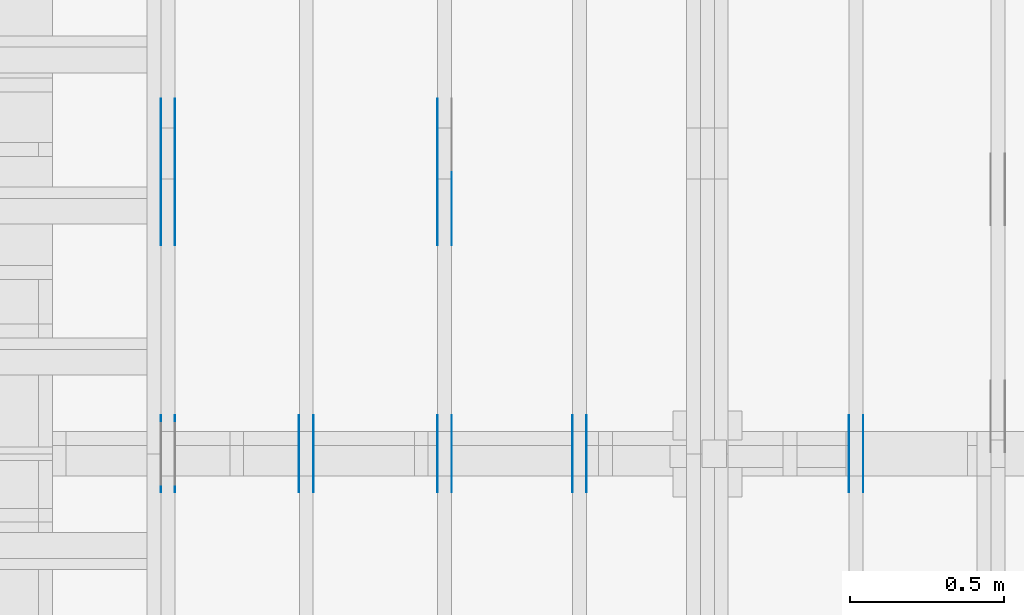
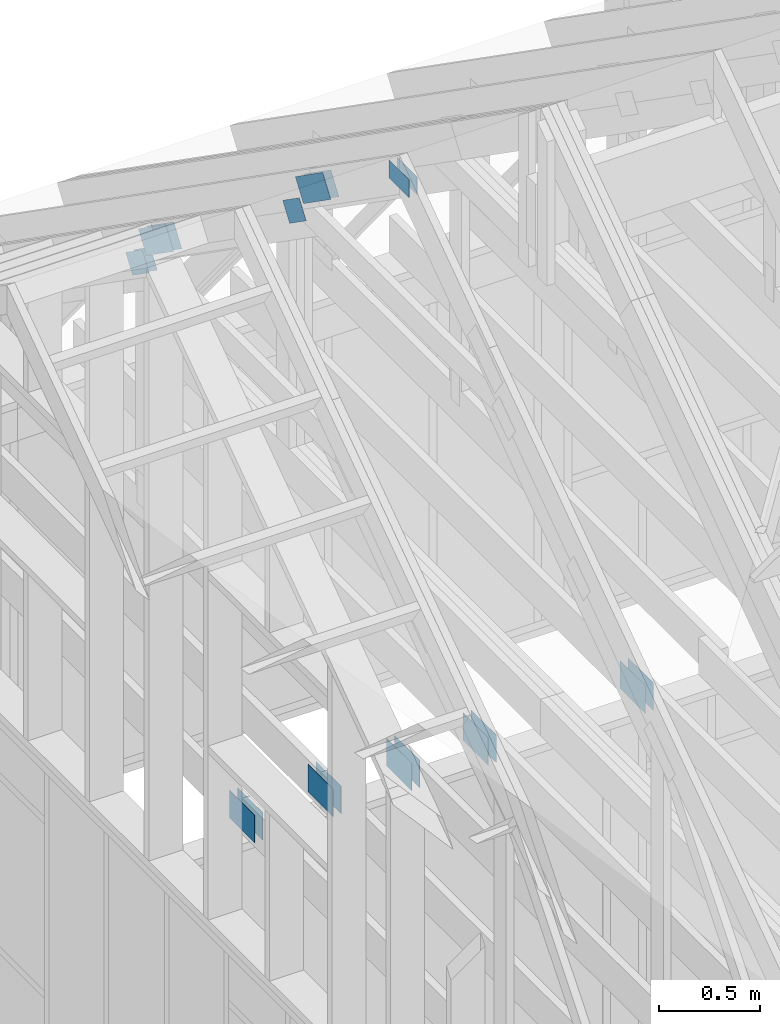
# One storey, part 47 of 70: 19 plates, 5 elements without a shape of their own.
"""IFC2X3 building model written with IfcOpenShell, lengths in millimetres."""

from ifc_helpers import new_model, si_unit, frame, origin, origin_with_axes, origin_2d, place, context, project, spatial, faceted_brep, element, aggregate, save


model = new_model("IFC2X3")

# Units and contexts
model_context = context("Model", 3, precision=1e-05, world=origin())
plan_context = context("Plan", 2, precision=1e-05, world=origin_2d())
ifc_project = project(units=[si_unit("LENGTHUNIT", "METRE", prefix="MILLI"), si_unit("AREAUNIT", "SQUARE_METRE"), si_unit("VOLUMEUNIT", "CUBIC_METRE"), si_unit("SOLIDANGLEUNIT", "STERADIAN"), si_unit("PLANEANGLEUNIT", "RADIAN"), si_unit("MASSUNIT", "GRAM"), si_unit("TIMEUNIT", "SECOND"), si_unit("THERMODYNAMICTEMPERATUREUNIT", "DEGREE_CELSIUS"), si_unit("LUMINOUSINTENSITYUNIT", "LUMEN")], contexts=[model_context, plan_context])

# Site, building, storey
site_placement = place(None, origin_with_axes())
site = spatial("IfcSite", under=ifc_project, at=site_placement, CompositionType="ELEMENT")
building_placement = place(site_placement, origin_with_axes())
building = spatial("IfcBuilding", under=site, at=building_placement, Name="Layout 1", CompositionType="ELEMENT")
storey_placement = place(building_placement, origin_with_axes())
storey = spatial("IfcBuildingStorey", under=building, at=storey_placement, Name="Storey 1", CompositionType="ELEMENT", Elevation=0.0)

# Assembly, plates
assembly_1_placement = place(storey_placement, frame((304.9999999999989, 8000.000000000001, 1.3776821480501744e-15), z_axis=(-1.0, 1.836909530733566e-16, 6.123031769111886e-17), x_axis=(-1.836909530733566e-16, -1.0, 0.0)))
assembly_1 = element("IfcElementAssembly", 1, at=assembly_1_placement, inside=storey, Name="T2", AssemblyPlace="FACTORY", PredefinedType="TRUSS")
plate_1_placement = place(assembly_1_placement, frame((3241.212504107585, 3235.9501271276167, 0.0), z_axis=(0.0, 0.0, 1.0), x_axis=(-0.8191520442889914, -0.5735764363510467, 0.0)))
plate_1 = element("IfcPlate", 2, at=plate_1_placement, context=model_context, shape_type="Brep", body=[
    faceted_brep([(330.0000000000009, 140.00000000000045, 1.5), (134.0000000000009, 140.00000000000045, 1.5), (134.0, 4.547473508864641e-13, 1.5), (330.0000000000009, 4.547473508864641e-13, 1.5), (133.9000001978775, 140.00000000000045, 1.5), (9.094947017729282e-13, 140.00000000000045, 1.5), (0.0, 4.547473508864641e-13, 1.5), (133.90000101970236, 4.547473508864641e-13, 1.5), (330.0000000000009, 140.00000000000045, 0.0), (134.0000000000009, 140.00000000000045, 0.0), (134.0, 4.547473508864641e-13, 0.0), (330.0000000000009, 4.547473508864641e-13, 0.0), (133.9000001978775, 140.00000000000045, 0.0), (9.094947017729282e-13, 140.00000000000045, 0.0), (0.0, 4.547473508864641e-13, 0.0), (133.90000101970236, 4.547473508864641e-13, 0.0), (330.0000000000009, 9.803270933743405e-13, -4.610357698653557e-29), (330.0000000000009, 9.804189388508772e-13, 1.5), (134.0, 6.682564251308046e-13, 1.5), (134.0, 6.681645796542679e-13, -4.091192948218372e-29), (133.90000101970236, 6.680053146896804e-13, 8.643095081543955e-31), (133.90000101970236, 6.680971601662171e-13, 1.5), (-1.4627915729340467e-31, 4.548391963630008e-13, 1.5), (0.0, 4.547473508864641e-13, 0.0), (133.90000101970236, 140.00000000000068, 5.032059779604519e-23), (133.90000101970236, 140.00000000000068, 1.5), (133.90000101970236, 6.821210263296962e-13, 1.5), (133.90000101970236, 6.821210263296962e-13, 0.0), (9.094947017729282e-13, 140.00000000000045, 0.0), (9.094947017729282e-13, 140.00000000000045, 1.5), (133.9000001978775, 140.00000000000068, 1.5), (133.9000001978775, 140.00000000000068, 1.5777218104420236e-30), (134.0000000000009, 140.00000000000068, 1.4199496293978212e-29), (134.0000000000009, 140.00000000000068, 1.5), (330.0000000000009, 140.00000000000102, 1.5), (330.0000000000009, 140.00000000000102, 2.208810534618833e-29), (5.56886495279458e-29, 4.547473508864641e-13, -3.409833702385498e-45), (9.184547653673398e-17, 4.547473508864641e-13, 1.5), (8.876511857361728e-13, 140.00000000000045, 1.5), (8.875593402596361e-13, 140.00000000000045, 1.3431091541284187e-30), (330.0000000000009, 140.00000000000068, 0.0), (330.0000000000009, 140.00000000000068, 1.5), (330.0000000000009, 2.2737367544323206e-13, 1.5), (330.0000000000009, 2.2737367544323206e-13, 0.0), (134.0, 0.0, 0.0), (134.0, 0.0, 1.5), (134.00000000000088, 140.00000000000045, 1.5), (134.00000000000088, 140.00000000000045, 1.5777218104420236e-30)], [[[0, 1, 2, 3]], [[4, 5, 6, 7]], [[8, 9, 10, 11]], [[12, 13, 14, 15]], [[16, 17, 18, 19]], [[20, 21, 22, 23]], [[24, 25, 26, 27]], [[28, 29, 30, 31]], [[32, 33, 34, 35]], [[36, 37, 38, 39]], [[40, 41, 42, 43]], [[44, 45, 46, 47]]]),
])
plate_2_placement = place(assembly_1_placement, frame((3241.212504107585, 3235.9501271276167, -46.5), z_axis=(0.0, 0.0, 1.0), x_axis=(-0.8191520442889914, -0.5735764363510467, 0.0)))
plate_2 = element("IfcPlate", 3, at=plate_2_placement, context=model_context, shape_type="Brep", body=[
    faceted_brep([(330.0000000000009, 140.00000000000045, 0.0), (134.0000000000009, 140.00000000000045, 0.0), (134.0, 4.547473508864641e-13, 0.0), (330.0000000000009, 4.547473508864641e-13, 0.0), (133.9000001978775, 140.00000000000045, 0.0), (9.094947017729282e-13, 140.00000000000045, 0.0), (0.0, 4.547473508864641e-13, 0.0), (133.90000101970236, 4.547473508864641e-13, 0.0), (330.0000000000009, 140.00000000000045, 1.5), (134.0000000000009, 140.00000000000045, 1.5), (134.0, 4.547473508864641e-13, 1.5), (330.0000000000009, 4.547473508864641e-13, 1.5), (133.9000001978775, 140.00000000000045, 1.5), (9.094947017729282e-13, 140.00000000000045, 1.5), (0.0, 4.547473508864641e-13, 1.5), (133.90000101970236, 4.547473508864641e-13, 1.5), (0.0, 4.547473508864641e-13, 0.0), (1.575266127070707e-31, 4.5465550540992744e-13, 1.5), (133.90000101970236, 6.843109484156988e-13, 1.5), (133.90000101970236, 6.844027938922355e-13, 1.397133527515671e-31), (134.0, 6.845743047954878e-13, 4.191670216580455e-29), (134.0, 6.844824593189511e-13, 1.5), (330.0000000000009, 1.0206472575739425e-12, 1.5), (330.0000000000009, 1.0207391030504792e-12, 4.85780171775421e-29), (133.90000101970236, 6.821210263296962e-13, 0.0), (133.90000101970236, 6.821210263296962e-13, 1.5), (133.90000019787752, 140.00000000000068, 1.5), (133.90000019787752, 140.00000000000068, 0.0), (330.0000000000009, 140.00000000000097, -1.8932661725304283e-29), (330.0000000000009, 140.00000000000097, 1.5), (134.00000000000094, 140.00000000000068, 1.5), (134.00000000000094, 140.00000000000068, -1.262177448353619e-29), (133.90000019787752, 140.00000000000068, 0.0), (133.90000019787752, 140.00000000000068, 1.5), (9.094947017729282e-13, 140.00000000000045, 1.5), (9.094947017729282e-13, 140.00000000000045, 0.0), (-2.8272774843121063e-27, 140.00000000000045, -5.568864952794597e-29), (-9.184547653950557e-17, 140.00000000000045, 1.5), (-9.184547653950557e-17, 4.547473508864641e-13, 1.5), (-2.8272774843121063e-27, 4.547473508864641e-13, -1.731150985653776e-43), (330.0000000000009, 2.2737367544323206e-13, 0.0), (330.0000000000009, 2.2737367544323206e-13, 1.5), (330.0000000000009, 140.00000000000068, 1.5), (330.0000000000009, 140.00000000000068, 0.0), (134.0, 140.00000000000045, -5.522026336547083e-29), (134.0, 140.00000000000045, 1.5), (134.0, 0.0, 1.5), (134.0, 0.0, 0.0)], [[[0, 1, 2, 3]], [[4, 5, 6, 7]], [[8, 9, 10, 11]], [[12, 13, 14, 15]], [[16, 17, 18, 19]], [[20, 21, 22, 23]], [[24, 25, 26, 27]], [[28, 29, 30, 31]], [[32, 33, 34, 35]], [[36, 37, 38, 39]], [[40, 41, 42, 43]], [[44, 45, 46, 47]]]),
])
plate_3_placement = place(assembly_1_placement, frame((4125.0, 194.0, 0.0), z_axis=(0.0, 0.0, 1.0), x_axis=(-1.0, 1.2246063538223773e-16, 0.0)))
plate_3 = element("IfcPlate", 4, at=plate_3_placement, context=model_context, shape_type="Brep", body=[
    faceted_brep([(250.0, 168.0, 1.3), (0.0, 168.0, 1.3), (0.0, 0.0, 1.3), (250.0, 0.0, 1.3), (0.0, 168.0, 0.0), (250.0, 168.0, 3.061515884555943e-14), (250.0, 0.0, 3.061515884555943e-14), (0.0, 0.0, 0.0), (250.0, -4.592273826833915e-14, 2.8118638534165077e-30), (250.0, -4.5843138855340694e-14, 1.3), (1.4621692037765842e-32, 7.959941299845453e-17, 1.3), (0.0, 0.0, 0.0), (250.0, 168.0, 0.0), (250.0, 168.0, 1.3), (250.0, 0.0, 1.3), (250.0, 0.0, 0.0), (0.0, 168.0, 0.0), (-4.8738973459219465e-33, 168.0, 1.3), (250.0, 167.99999999999997, 1.3), (250.0, 167.99999999999997, -1.5777218104420236e-30), (0.0, 0.0, 0.0), (7.959941299845453e-17, -9.747794691843893e-33, 1.3), (2.065298615721439e-14, 168.0, 1.3), (2.0573386744215938e-14, 168.0, -1.2597150063305954e-30)], [[[0, 1, 2, 3]], [[4, 5, 6, 7]], [[8, 9, 10, 11]], [[12, 13, 14, 15]], [[16, 17, 18, 19]], [[20, 21, 22, 23]]]),
])
plate_4_placement = place(assembly_1_placement, frame((4125.0, 194.0, -46.3), z_axis=(0.0, 0.0, 1.0), x_axis=(-1.0, 1.2246063538223773e-16, 0.0)))
plate_4 = element("IfcPlate", 5, at=plate_4_placement, context=model_context, shape_type="Brep", body=[
    faceted_brep([(250.0, 168.0, 1.2999999999999972), (0.0, 168.0, 1.2999999999999972), (0.0, 0.0, 1.2999999999999972), (250.0, 0.0, 1.2999999999999972), (0.0, 168.0, 0.0), (250.0, 168.0, 3.061515884555943e-14), (250.0, 0.0, 3.061515884555943e-14), (0.0, 0.0, 0.0), (250.0, -4.592273826833915e-14, 2.8118638534165077e-30), (250.0, -4.5843138855340694e-14, 1.2999999999999972), (1.462169203776581e-32, 7.959941299845434e-17, 1.2999999999999972), (0.0, 0.0, 0.0), (250.0, 168.0, 0.0), (250.0, 168.0, 1.2999999999999972), (250.0, 0.0, 1.2999999999999972), (250.0, 0.0, 0.0), (0.0, 168.0, 0.0), (-4.873897345921936e-33, 168.0, 1.2999999999999972), (250.0, 167.99999999999997, 1.2999999999999972), (250.0, 167.99999999999997, -1.5777218104420236e-30), (0.0, 0.0, 0.0), (7.959941299845434e-17, -9.747794691843873e-33, 1.2999999999999972), (2.065298615721439e-14, 168.0, 1.2999999999999972), (2.0573386744215938e-14, 168.0, -1.2597150063305954e-30)], [[[0, 1, 2, 3]], [[4, 5, 6, 7]], [[8, 9, 10, 11]], [[12, 13, 14, 15]], [[16, 17, 18, 19]], [[20, 21, 22, 23]]]),
])
plate_5_placement = place(assembly_1_placement, frame((2913.5449336778356, 2728.78860534236, 0.0), z_axis=(0.0, 0.0, 1.0), x_axis=(0.8191520442889915, 0.5735764363510465, 0.0)))
plate_5 = element("IfcPlate", 6, at=plate_5_placement, context=model_context, shape_type="Brep", body=[
    faceted_brep([(200.0, 120.00000000000023, 1.3), (0.0, 120.00000000000023, 1.3), (0.0, 0.0, 1.3), (200.0, 0.0, 1.3), (0.0, 120.00000000000023, 0.0), (200.0, 120.00000000000023, 2.4492127076447545e-14), (200.0, 4.547473508864641e-13, 2.4492127076447545e-14), (0.0, 4.547473508864641e-13, 0.0), (200.0, 3.185331772653788e-13, 8.340437124852278e-30), (200.0, 3.186127766783772e-13, 1.3), (-1.2677526965428406e-31, 7.959941299845453e-17, 1.3), (0.0, 0.0, 0.0), (200.0, 120.00000000000023, 0.0), (200.0, 120.00000000000023, 1.3), (200.0, 4.547473508864641e-13, 1.3), (200.0, 4.547473508864641e-13, 0.0), (0.0, 120.00000000000023, 0.0), (-4.8738973459219465e-33, 120.00000000000023, 1.3), (200.0, 120.00000000000021, 1.3), (200.0, 120.00000000000021, 0.0), (0.0, 0.0, 0.0), (7.959941299845453e-17, -9.747794691843893e-33, 1.3), (1.477487565886701e-14, 120.00000000000023, 1.3), (1.4695276245868555e-14, 120.00000000000023, -8.997964330932842e-31)], [[[0, 1, 2, 3]], [[4, 5, 6, 7]], [[8, 9, 10, 11]], [[12, 13, 14, 15]], [[16, 17, 18, 19]], [[20, 21, 22, 23]]]),
])
plate_6_placement = place(assembly_1_placement, frame((2913.5449336778356, 2728.78860534236, -46.29999999999999), z_axis=(0.0, 0.0, 1.0), x_axis=(0.8191520442889915, 0.5735764363510465, 0.0)))
plate_6 = element("IfcPlate", 7, at=plate_6_placement, context=model_context, shape_type="Brep", body=[
    faceted_brep([(200.0, 120.00000000000023, 1.2999999999999972), (0.0, 120.00000000000023, 1.2999999999999972), (0.0, 0.0, 1.2999999999999972), (200.0, 0.0, 1.2999999999999972), (0.0, 120.00000000000023, 0.0), (200.0, 120.00000000000023, 2.4492127076447545e-14), (200.0, 4.547473508864641e-13, 2.4492127076447545e-14), (0.0, 4.547473508864641e-13, 0.0), (200.0, 3.185331772653788e-13, 8.340437124852278e-30), (200.0, 3.186127766783772e-13, 1.2999999999999972), (-1.2677526965428377e-31, 7.959941299845434e-17, 1.2999999999999972), (0.0, 0.0, 0.0), (200.0, 120.00000000000023, 0.0), (200.0, 120.00000000000023, 1.2999999999999972), (200.0, 4.547473508864641e-13, 1.2999999999999972), (200.0, 4.547473508864641e-13, 0.0), (0.0, 120.00000000000023, 0.0), (-4.873897345921936e-33, 120.00000000000023, 1.2999999999999972), (200.0, 120.00000000000021, 1.2999999999999972), (200.0, 120.00000000000021, 0.0), (0.0, 0.0, 0.0), (7.959941299845434e-17, -9.747794691843873e-33, 1.2999999999999972), (1.477487565886701e-14, 120.00000000000023, 1.2999999999999972), (1.4695276245868555e-14, 120.00000000000023, -8.997964330932842e-31)], [[[0, 1, 2, 3]], [[4, 5, 6, 7]], [[8, 9, 10, 11]], [[12, 13, 14, 15]], [[16, 17, 18, 19]], [[20, 21, 22, 23]]]),
])
aggregate(assembly_1, [plate_1, plate_2, plate_3, plate_4, plate_5, plate_6])

assembly_2_placement = place(storey_placement, frame((1204.9999999999989, 8000.000000000001, 1.3776821480501744e-15), z_axis=(-1.0, 1.836909530733566e-16, 6.123031769111886e-17), x_axis=(-1.836909530733566e-16, -1.0, 0.0)))
assembly_2 = element("IfcElementAssembly", 8, at=assembly_2_placement, inside=storey, Name="T2", AssemblyPlace="FACTORY", PredefinedType="TRUSS")
plate_7_placement = place(assembly_2_placement, frame((3241.212504107585, 3235.9501271276167, 0.0), z_axis=(0.0, 0.0, 1.0), x_axis=(-0.8191520442889914, -0.5735764363510467, 0.0)))
plate_7 = element("IfcPlate", 9, at=plate_7_placement, context=model_context, shape_type="Brep", body=[
    faceted_brep([(330.0000000000009, 140.00000000000045, 1.5), (134.0000000000009, 140.00000000000045, 1.5), (134.0, 4.547473508864641e-13, 1.5), (330.0000000000009, 4.547473508864641e-13, 1.5), (133.9000001978775, 140.00000000000045, 1.5), (9.094947017729282e-13, 140.00000000000045, 1.5), (0.0, 4.547473508864641e-13, 1.5), (133.90000101970236, 4.547473508864641e-13, 1.5), (330.0000000000009, 140.00000000000045, 0.0), (134.0000000000009, 140.00000000000045, 0.0), (134.0, 4.547473508864641e-13, 0.0), (330.0000000000009, 4.547473508864641e-13, 0.0), (133.9000001978775, 140.00000000000045, 0.0), (9.094947017729282e-13, 140.00000000000045, 0.0), (0.0, 4.547473508864641e-13, 0.0), (133.90000101970236, 4.547473508864641e-13, 0.0), (330.0000000000009, 9.803270933743405e-13, -4.610357698653557e-29), (330.0000000000009, 9.804189388508772e-13, 1.5), (134.0, 6.682564251308046e-13, 1.5), (134.0, 6.681645796542679e-13, -4.091192948218372e-29), (133.90000101970236, 6.680053146896804e-13, 8.643095081543955e-31), (133.90000101970236, 6.680971601662171e-13, 1.5), (-1.4627915729340467e-31, 4.548391963630008e-13, 1.5), (0.0, 4.547473508864641e-13, 0.0), (133.90000101970236, 140.00000000000068, 5.032059779604519e-23), (133.90000101970236, 140.00000000000068, 1.5), (133.90000101970236, 6.821210263296962e-13, 1.5), (133.90000101970236, 6.821210263296962e-13, 0.0), (9.094947017729282e-13, 140.00000000000045, 0.0), (9.094947017729282e-13, 140.00000000000045, 1.5), (133.9000001978775, 140.00000000000068, 1.5), (133.9000001978775, 140.00000000000068, 1.5777218104420236e-30), (134.0000000000009, 140.00000000000068, 1.4199496293978212e-29), (134.0000000000009, 140.00000000000068, 1.5), (330.0000000000009, 140.00000000000102, 1.5), (330.0000000000009, 140.00000000000102, 2.208810534618833e-29), (5.56886495279458e-29, 4.547473508864641e-13, -3.409833702385498e-45), (9.184547653673398e-17, 4.547473508864641e-13, 1.5), (8.876511857361728e-13, 140.00000000000045, 1.5), (8.875593402596361e-13, 140.00000000000045, 1.3431091541284187e-30), (330.0000000000009, 140.00000000000068, 0.0), (330.0000000000009, 140.00000000000068, 1.5), (330.0000000000009, 2.2737367544323206e-13, 1.5), (330.0000000000009, 2.2737367544323206e-13, 0.0), (134.0, 0.0, 0.0), (134.0, 0.0, 1.5), (134.00000000000088, 140.00000000000045, 1.5), (134.00000000000088, 140.00000000000045, 1.5777218104420236e-30)], [[[0, 1, 2, 3]], [[4, 5, 6, 7]], [[8, 9, 10, 11]], [[12, 13, 14, 15]], [[16, 17, 18, 19]], [[20, 21, 22, 23]], [[24, 25, 26, 27]], [[28, 29, 30, 31]], [[32, 33, 34, 35]], [[36, 37, 38, 39]], [[40, 41, 42, 43]], [[44, 45, 46, 47]]]),
])
plate_8_placement = place(assembly_2_placement, frame((3241.212504107585, 3235.9501271276167, -46.5), z_axis=(0.0, 0.0, 1.0), x_axis=(-0.8191520442889914, -0.5735764363510467, 0.0)))
plate_8 = element("IfcPlate", 10, at=plate_8_placement, context=model_context, shape_type="Brep", body=[
    faceted_brep([(330.0000000000009, 140.00000000000045, 0.0), (134.0000000000009, 140.00000000000045, 0.0), (134.0, 4.547473508864641e-13, 0.0), (330.0000000000009, 4.547473508864641e-13, 0.0), (133.9000001978775, 140.00000000000045, 0.0), (9.094947017729282e-13, 140.00000000000045, 0.0), (0.0, 4.547473508864641e-13, 0.0), (133.90000101970236, 4.547473508864641e-13, 0.0), (330.0000000000009, 140.00000000000045, 1.5), (134.0000000000009, 140.00000000000045, 1.5), (134.0, 4.547473508864641e-13, 1.5), (330.0000000000009, 4.547473508864641e-13, 1.5), (133.9000001978775, 140.00000000000045, 1.5), (9.094947017729282e-13, 140.00000000000045, 1.5), (0.0, 4.547473508864641e-13, 1.5), (133.90000101970236, 4.547473508864641e-13, 1.5), (0.0, 4.547473508864641e-13, 0.0), (1.575266127070707e-31, 4.5465550540992744e-13, 1.5), (133.90000101970236, 6.843109484156988e-13, 1.5), (133.90000101970236, 6.844027938922355e-13, 1.397133527515671e-31), (134.0, 6.845743047954878e-13, 4.191670216580455e-29), (134.0, 6.844824593189511e-13, 1.5), (330.0000000000009, 1.0206472575739425e-12, 1.5), (330.0000000000009, 1.0207391030504792e-12, 4.85780171775421e-29), (133.90000101970236, 6.821210263296962e-13, 0.0), (133.90000101970236, 6.821210263296962e-13, 1.5), (133.90000019787752, 140.00000000000068, 1.5), (133.90000019787752, 140.00000000000068, 0.0), (330.0000000000009, 140.00000000000097, -1.8932661725304283e-29), (330.0000000000009, 140.00000000000097, 1.5), (134.00000000000094, 140.00000000000068, 1.5), (134.00000000000094, 140.00000000000068, -1.262177448353619e-29), (133.90000019787752, 140.00000000000068, 0.0), (133.90000019787752, 140.00000000000068, 1.5), (9.094947017729282e-13, 140.00000000000045, 1.5), (9.094947017729282e-13, 140.00000000000045, 0.0), (-2.8272774843121063e-27, 140.00000000000045, -5.568864952794597e-29), (-9.184547653950557e-17, 140.00000000000045, 1.5), (-9.184547653950557e-17, 4.547473508864641e-13, 1.5), (-2.8272774843121063e-27, 4.547473508864641e-13, -1.731150985653776e-43), (330.0000000000009, 2.2737367544323206e-13, 0.0), (330.0000000000009, 2.2737367544323206e-13, 1.5), (330.0000000000009, 140.00000000000068, 1.5), (330.0000000000009, 140.00000000000068, 0.0), (134.0, 140.00000000000045, -5.522026336547083e-29), (134.0, 140.00000000000045, 1.5), (134.0, 0.0, 1.5), (134.0, 0.0, 0.0)], [[[0, 1, 2, 3]], [[4, 5, 6, 7]], [[8, 9, 10, 11]], [[12, 13, 14, 15]], [[16, 17, 18, 19]], [[20, 21, 22, 23]], [[24, 25, 26, 27]], [[28, 29, 30, 31]], [[32, 33, 34, 35]], [[36, 37, 38, 39]], [[40, 41, 42, 43]], [[44, 45, 46, 47]]]),
])
plate_9_placement = place(assembly_2_placement, frame((3899.9999999999995, 3603.8046304341406, 0.0), z_axis=(0.0, 0.0, 1.0), x_axis=(1.0, 0.0, 0.0)))
plate_9 = element("IfcPlate", 11, at=plate_9_placement, context=model_context, shape_type="Brep", body=[
    faceted_brep([(200.00000000000045, 108.0, 1.3), (0.0, 108.0, 1.3), (0.0, 0.0, 1.3), (200.00000000000045, 0.0, 1.3), (0.0, 108.0, 0.0), (200.00000000000045, 108.0, 2.4492127076447602e-14), (200.00000000000045, 0.0, 2.4492127076447602e-14), (0.0, 0.0, 0.0), (200.00000000000045, -3.67381906146714e-14, 2.2494910827332114e-30), (200.00000000000045, -3.6658591201672947e-14, 1.3), (1.4621692037765842e-32, 7.959941299845453e-17, 1.3), (0.0, 0.0, 0.0), (200.00000000000045, 108.0, 0.0), (200.00000000000045, 108.0, 1.3), (200.00000000000045, 0.0, 1.3), (200.00000000000045, 0.0, 0.0), (0.0, 108.0, 0.0), (-4.8738973459219465e-33, 108.0, 1.3), (200.00000000000045, 107.99999999999999, 1.3), (200.00000000000045, 107.99999999999999, -7.888609052210118e-31), (0.0, 0.0, 0.0), (7.959941299845453e-17, -9.747794691843893e-33, 1.3), (1.330534803428013e-14, 108.0, 1.3), (1.3225748621281674e-14, 108.0, -8.098167897839542e-31)], [[[0, 1, 2, 3]], [[4, 5, 6, 7]], [[8, 9, 10, 11]], [[12, 13, 14, 15]], [[16, 17, 18, 19]], [[20, 21, 22, 23]]]),
])
plate_10_placement = place(assembly_2_placement, frame((3899.9999999999995, 3603.8046304341406, -46.3), z_axis=(0.0, 0.0, 1.0), x_axis=(1.0, 0.0, 0.0)))
plate_10 = element("IfcPlate", 12, at=plate_10_placement, context=model_context, shape_type="Brep", body=[
    faceted_brep([(200.00000000000045, 108.0, 1.2999999999999972), (0.0, 108.0, 1.2999999999999972), (0.0, 0.0, 1.2999999999999972), (200.00000000000045, 0.0, 1.2999999999999972), (0.0, 108.0, 0.0), (200.00000000000045, 108.0, 2.4492127076447602e-14), (200.00000000000045, 0.0, 2.4492127076447602e-14), (0.0, 0.0, 0.0), (200.00000000000045, -3.67381906146714e-14, 2.2494910827332114e-30), (200.00000000000045, -3.6658591201672947e-14, 1.2999999999999972), (1.462169203776581e-32, 7.959941299845434e-17, 1.2999999999999972), (0.0, 0.0, 0.0), (200.00000000000045, 108.0, 0.0), (200.00000000000045, 108.0, 1.2999999999999972), (200.00000000000045, 0.0, 1.2999999999999972), (200.00000000000045, 0.0, 0.0), (0.0, 108.0, 0.0), (-4.873897345921936e-33, 108.0, 1.2999999999999972), (200.00000000000045, 107.99999999999999, 1.2999999999999972), (200.00000000000045, 107.99999999999999, -7.888609052210118e-31), (0.0, 0.0, 0.0), (7.959941299845434e-17, -9.747794691843873e-33, 1.2999999999999972), (1.330534803428013e-14, 108.0, 1.2999999999999972), (1.3225748621281674e-14, 108.0, -8.098167897839542e-31)], [[[0, 1, 2, 3]], [[4, 5, 6, 7]], [[8, 9, 10, 11]], [[12, 13, 14, 15]], [[16, 17, 18, 19]], [[20, 21, 22, 23]]]),
])
plate_11_placement = place(assembly_2_placement, frame((4125.0, 194.0, 0.0), z_axis=(0.0, 0.0, 1.0), x_axis=(-1.0, 1.2246063538223773e-16, 0.0)))
plate_11 = element("IfcPlate", 13, at=plate_11_placement, context=model_context, shape_type="Brep", body=[
    faceted_brep([(250.0, 168.0, 1.3), (0.0, 168.0, 1.3), (0.0, 0.0, 1.3), (250.0, 0.0, 1.3), (0.0, 168.0, 0.0), (250.0, 168.0, 3.061515884555943e-14), (250.0, 0.0, 3.061515884555943e-14), (0.0, 0.0, 0.0), (250.0, -4.592273826833915e-14, 2.8118638534165077e-30), (250.0, -4.5843138855340694e-14, 1.3), (1.4621692037765842e-32, 7.959941299845453e-17, 1.3), (0.0, 0.0, 0.0), (250.0, 168.0, 0.0), (250.0, 168.0, 1.3), (250.0, 0.0, 1.3), (250.0, 0.0, 0.0), (0.0, 168.0, 0.0), (-4.8738973459219465e-33, 168.0, 1.3), (250.0, 167.99999999999997, 1.3), (250.0, 167.99999999999997, -1.5777218104420236e-30), (0.0, 0.0, 0.0), (7.959941299845453e-17, -9.747794691843893e-33, 1.3), (2.065298615721439e-14, 168.0, 1.3), (2.0573386744215938e-14, 168.0, -1.2597150063305954e-30)], [[[0, 1, 2, 3]], [[4, 5, 6, 7]], [[8, 9, 10, 11]], [[12, 13, 14, 15]], [[16, 17, 18, 19]], [[20, 21, 22, 23]]]),
])
plate_12_placement = place(assembly_2_placement, frame((4125.0, 194.0, -46.3), z_axis=(0.0, 0.0, 1.0), x_axis=(-1.0, 1.2246063538223773e-16, 0.0)))
plate_12 = element("IfcPlate", 14, at=plate_12_placement, context=model_context, shape_type="Brep", body=[
    faceted_brep([(250.0, 168.0, 1.2999999999999972), (0.0, 168.0, 1.2999999999999972), (0.0, 0.0, 1.2999999999999972), (250.0, 0.0, 1.2999999999999972), (0.0, 168.0, 0.0), (250.0, 168.0, 3.061515884555943e-14), (250.0, 0.0, 3.061515884555943e-14), (0.0, 0.0, 0.0), (250.0, -4.592273826833915e-14, 2.8118638534165077e-30), (250.0, -4.5843138855340694e-14, 1.2999999999999972), (1.462169203776581e-32, 7.959941299845434e-17, 1.2999999999999972), (0.0, 0.0, 0.0), (250.0, 168.0, 0.0), (250.0, 168.0, 1.2999999999999972), (250.0, 0.0, 1.2999999999999972), (250.0, 0.0, 0.0), (0.0, 168.0, 0.0), (-4.873897345921936e-33, 168.0, 1.2999999999999972), (250.0, 167.99999999999997, 1.2999999999999972), (250.0, 167.99999999999997, -1.5777218104420236e-30), (0.0, 0.0, 0.0), (7.959941299845434e-17, -9.747794691843873e-33, 1.2999999999999972), (2.065298615721439e-14, 168.0, 1.2999999999999972), (2.0573386744215938e-14, 168.0, -1.2597150063305954e-30)], [[[0, 1, 2, 3]], [[4, 5, 6, 7]], [[8, 9, 10, 11]], [[12, 13, 14, 15]], [[16, 17, 18, 19]], [[20, 21, 22, 23]]]),
])
plate_13_placement = place(assembly_2_placement, frame((2913.5449336778356, 2728.78860534236, 0.0), z_axis=(0.0, 0.0, 1.0), x_axis=(0.8191520442889915, 0.5735764363510465, 0.0)))
plate_13 = element("IfcPlate", 15, at=plate_13_placement, context=model_context, shape_type="Brep", body=[
    faceted_brep([(200.0, 120.00000000000023, 1.3), (0.0, 120.00000000000023, 1.3), (0.0, 0.0, 1.3), (200.0, 0.0, 1.3), (0.0, 120.00000000000023, 0.0), (200.0, 120.00000000000023, 2.4492127076447545e-14), (200.0, 4.547473508864641e-13, 2.4492127076447545e-14), (0.0, 4.547473508864641e-13, 0.0), (200.0, 3.185331772653788e-13, 8.340437124852278e-30), (200.0, 3.186127766783772e-13, 1.3), (-1.2677526965428406e-31, 7.959941299845453e-17, 1.3), (0.0, 0.0, 0.0), (200.0, 120.00000000000023, 0.0), (200.0, 120.00000000000023, 1.3), (200.0, 4.547473508864641e-13, 1.3), (200.0, 4.547473508864641e-13, 0.0), (0.0, 120.00000000000023, 0.0), (-4.8738973459219465e-33, 120.00000000000023, 1.3), (200.0, 120.00000000000021, 1.3), (200.0, 120.00000000000021, 0.0), (0.0, 0.0, 0.0), (7.959941299845453e-17, -9.747794691843893e-33, 1.3), (1.477487565886701e-14, 120.00000000000023, 1.3), (1.4695276245868555e-14, 120.00000000000023, -8.997964330932842e-31)], [[[0, 1, 2, 3]], [[4, 5, 6, 7]], [[8, 9, 10, 11]], [[12, 13, 14, 15]], [[16, 17, 18, 19]], [[20, 21, 22, 23]]]),
])
aggregate(assembly_2, [plate_7, plate_8, plate_9, plate_10, plate_11, plate_12, plate_13])

assembly_3_placement = place(storey_placement, frame((754.9999999999991, 8000.000000000001, 1.3776821480501744e-15), z_axis=(-1.0, 1.836909530733566e-16, 6.123031769111886e-17), x_axis=(-1.836909530733566e-16, -1.0, 0.0)))
assembly_3 = element("IfcElementAssembly", 16, at=assembly_3_placement, inside=storey, Name="MB1", AssemblyPlace="FACTORY", PredefinedType="TRUSS")
plate_14_placement = place(assembly_3_placement, frame((4125.0, 193.99999999999994, 0.0), z_axis=(0.0, 0.0, 1.0), x_axis=(-1.0, 1.2246063538223773e-16, 0.0)))
plate_14 = element("IfcPlate", 17, at=plate_14_placement, context=model_context, shape_type="Brep", body=[
    faceted_brep([(250.0, 168.0, 1.3), (0.0, 168.0, 1.3), (0.0, 0.0, 1.3), (250.0, 0.0, 1.3), (0.0, 168.0, 0.0), (250.0, 168.0, 3.061515884555943e-14), (250.0, 0.0, 3.061515884555943e-14), (0.0, 0.0, 0.0), (250.0, -4.592273826833915e-14, 2.8118638534165077e-30), (250.0, -4.5843138855340694e-14, 1.3), (1.4621692037765842e-32, 7.959941299845453e-17, 1.3), (0.0, 0.0, 0.0), (250.0, 168.0, 0.0), (250.0, 168.0, 1.3), (250.0, 0.0, 1.3), (250.0, 0.0, 0.0), (0.0, 168.0, 0.0), (-4.8738973459219465e-33, 168.0, 1.3), (250.0, 167.99999999999997, 1.3), (250.0, 167.99999999999997, -1.5777218104420236e-30), (0.0, 0.0, 0.0), (7.959941299845453e-17, -9.747794691843893e-33, 1.3), (2.065298615721439e-14, 168.0, 1.3), (2.0573386744215938e-14, 168.0, -1.2597150063305954e-30)], [[[0, 1, 2, 3]], [[4, 5, 6, 7]], [[8, 9, 10, 11]], [[12, 13, 14, 15]], [[16, 17, 18, 19]], [[20, 21, 22, 23]]]),
])
plate_15_placement = place(assembly_3_placement, frame((4125.0, 193.99999999999994, -46.3), z_axis=(0.0, 0.0, 1.0), x_axis=(-1.0, 1.2246063538223773e-16, 0.0)))
plate_15 = element("IfcPlate", 18, at=plate_15_placement, context=model_context, shape_type="Brep", body=[
    faceted_brep([(250.0, 168.0, 1.2999999999999972), (0.0, 168.0, 1.2999999999999972), (0.0, 0.0, 1.2999999999999972), (250.0, 0.0, 1.2999999999999972), (0.0, 168.0, 0.0), (250.0, 168.0, 3.061515884555943e-14), (250.0, 0.0, 3.061515884555943e-14), (0.0, 0.0, 0.0), (250.0, -4.592273826833915e-14, 2.8118638534165077e-30), (250.0, -4.5843138855340694e-14, 1.2999999999999972), (1.462169203776581e-32, 7.959941299845434e-17, 1.2999999999999972), (0.0, 0.0, 0.0), (250.0, 168.0, 0.0), (250.0, 168.0, 1.2999999999999972), (250.0, 0.0, 1.2999999999999972), (250.0, 0.0, 0.0), (0.0, 168.0, 0.0), (-4.873897345921936e-33, 168.0, 1.2999999999999972), (250.0, 167.99999999999997, 1.2999999999999972), (250.0, 167.99999999999997, -1.5777218104420236e-30), (0.0, 0.0, 0.0), (7.959941299845434e-17, -9.747794691843873e-33, 1.2999999999999972), (2.065298615721439e-14, 168.0, 1.2999999999999972), (2.0573386744215938e-14, 168.0, -1.2597150063305954e-30)], [[[0, 1, 2, 3]], [[4, 5, 6, 7]], [[8, 9, 10, 11]], [[12, 13, 14, 15]], [[16, 17, 18, 19]], [[20, 21, 22, 23]]]),
])
aggregate(assembly_3, [plate_14, plate_15])

assembly_4_placement = place(storey_placement, frame((1643.7499999999982, 8000.000000000001, 1.3776821480501744e-15), z_axis=(-1.0, 1.836909530733566e-16, 6.123031769111886e-17), x_axis=(-1.836909530733566e-16, -1.0, 0.0)))
assembly_4 = element("IfcElementAssembly", 19, at=assembly_4_placement, inside=storey, Name="MB1", AssemblyPlace="FACTORY", PredefinedType="TRUSS")
plate_16_placement = place(assembly_4_placement, frame((4125.0, 193.99999999999994, 0.0), z_axis=(0.0, 0.0, 1.0), x_axis=(-1.0, 1.2246063538223773e-16, 0.0)))
plate_16 = element("IfcPlate", 20, at=plate_16_placement, context=model_context, shape_type="Brep", body=[
    faceted_brep([(250.0, 168.0, 1.3), (0.0, 168.0, 1.3), (0.0, 0.0, 1.3), (250.0, 0.0, 1.3), (0.0, 168.0, 0.0), (250.0, 168.0, 3.061515884555943e-14), (250.0, 0.0, 3.061515884555943e-14), (0.0, 0.0, 0.0), (250.0, -4.592273826833915e-14, 2.8118638534165077e-30), (250.0, -4.5843138855340694e-14, 1.3), (1.4621692037765842e-32, 7.959941299845453e-17, 1.3), (0.0, 0.0, 0.0), (250.0, 168.0, 0.0), (250.0, 168.0, 1.3), (250.0, 0.0, 1.3), (250.0, 0.0, 0.0), (0.0, 168.0, 0.0), (-4.8738973459219465e-33, 168.0, 1.3), (250.0, 167.99999999999997, 1.3), (250.0, 167.99999999999997, -1.5777218104420236e-30), (0.0, 0.0, 0.0), (7.959941299845453e-17, -9.747794691843893e-33, 1.3), (2.065298615721439e-14, 168.0, 1.3), (2.0573386744215938e-14, 168.0, -1.2597150063305954e-30)], [[[0, 1, 2, 3]], [[4, 5, 6, 7]], [[8, 9, 10, 11]], [[12, 13, 14, 15]], [[16, 17, 18, 19]], [[20, 21, 22, 23]]]),
])
plate_17_placement = place(assembly_4_placement, frame((4125.0, 193.99999999999994, -46.3), z_axis=(0.0, 0.0, 1.0), x_axis=(-1.0, 1.2246063538223773e-16, 0.0)))
plate_17 = element("IfcPlate", 21, at=plate_17_placement, context=model_context, shape_type="Brep", body=[
    faceted_brep([(250.0, 168.0, 1.2999999999999972), (0.0, 168.0, 1.2999999999999972), (0.0, 0.0, 1.2999999999999972), (250.0, 0.0, 1.2999999999999972), (0.0, 168.0, 0.0), (250.0, 168.0, 3.061515884555943e-14), (250.0, 0.0, 3.061515884555943e-14), (0.0, 0.0, 0.0), (250.0, -4.592273826833915e-14, 2.8118638534165077e-30), (250.0, -4.5843138855340694e-14, 1.2999999999999972), (1.462169203776581e-32, 7.959941299845434e-17, 1.2999999999999972), (0.0, 0.0, 0.0), (250.0, 168.0, 0.0), (250.0, 168.0, 1.2999999999999972), (250.0, 0.0, 1.2999999999999972), (250.0, 0.0, 0.0), (0.0, 168.0, 0.0), (-4.873897345921936e-33, 168.0, 1.2999999999999972), (250.0, 167.99999999999997, 1.2999999999999972), (250.0, 167.99999999999997, -1.5777218104420236e-30), (0.0, 0.0, 0.0), (7.959941299845434e-17, -9.747794691843873e-33, 1.2999999999999972), (2.065298615721439e-14, 168.0, 1.2999999999999972), (2.0573386744215938e-14, 168.0, -1.2597150063305954e-30)], [[[0, 1, 2, 3]], [[4, 5, 6, 7]], [[8, 9, 10, 11]], [[12, 13, 14, 15]], [[16, 17, 18, 19]], [[20, 21, 22, 23]]]),
])
aggregate(assembly_4, [plate_16, plate_17])

assembly_5_placement = place(storey_placement, frame((2543.749999999999, 8000.000000000001, 1.3776821480501744e-15), z_axis=(-1.0, 1.836909530733566e-16, 6.123031769111886e-17), x_axis=(-1.836909530733566e-16, -1.0, 0.0)))
assembly_5 = element("IfcElementAssembly", 22, at=assembly_5_placement, inside=storey, Name="MB1", AssemblyPlace="FACTORY", PredefinedType="TRUSS")
plate_18_placement = place(assembly_5_placement, frame((4125.0, 193.99999999999994, 0.0), z_axis=(0.0, 0.0, 1.0), x_axis=(-1.0, 1.2246063538223773e-16, 0.0)))
plate_18 = element("IfcPlate", 23, at=plate_18_placement, context=model_context, shape_type="Brep", body=[
    faceted_brep([(250.0, 168.0, 1.3), (0.0, 168.0, 1.3), (0.0, 0.0, 1.3), (250.0, 0.0, 1.3), (0.0, 168.0, 0.0), (250.0, 168.0, 3.061515884555943e-14), (250.0, 0.0, 3.061515884555943e-14), (0.0, 0.0, 0.0), (250.0, -4.592273826833915e-14, 2.8118638534165077e-30), (250.0, -4.5843138855340694e-14, 1.3), (1.4621692037765842e-32, 7.959941299845453e-17, 1.3), (0.0, 0.0, 0.0), (250.0, 168.0, 0.0), (250.0, 168.0, 1.3), (250.0, 0.0, 1.3), (250.0, 0.0, 0.0), (0.0, 168.0, 0.0), (-4.8738973459219465e-33, 168.0, 1.3), (250.0, 167.99999999999997, 1.3), (250.0, 167.99999999999997, -1.5777218104420236e-30), (0.0, 0.0, 0.0), (7.959941299845453e-17, -9.747794691843893e-33, 1.3), (2.065298615721439e-14, 168.0, 1.3), (2.0573386744215938e-14, 168.0, -1.2597150063305954e-30)], [[[0, 1, 2, 3]], [[4, 5, 6, 7]], [[8, 9, 10, 11]], [[12, 13, 14, 15]], [[16, 17, 18, 19]], [[20, 21, 22, 23]]]),
])
plate_19_placement = place(assembly_5_placement, frame((4125.0, 193.99999999999994, -46.3), z_axis=(0.0, 0.0, 1.0), x_axis=(-1.0, 1.2246063538223773e-16, 0.0)))
plate_19 = element("IfcPlate", 24, at=plate_19_placement, context=model_context, shape_type="Brep", body=[
    faceted_brep([(250.0, 168.0, 1.2999999999999972), (0.0, 168.0, 1.2999999999999972), (0.0, 0.0, 1.2999999999999972), (250.0, 0.0, 1.2999999999999972), (0.0, 168.0, 0.0), (250.0, 168.0, 3.061515884555943e-14), (250.0, 0.0, 3.061515884555943e-14), (0.0, 0.0, 0.0), (250.0, -4.592273826833915e-14, 2.8118638534165077e-30), (250.0, -4.5843138855340694e-14, 1.2999999999999972), (1.462169203776581e-32, 7.959941299845434e-17, 1.2999999999999972), (0.0, 0.0, 0.0), (250.0, 168.0, 0.0), (250.0, 168.0, 1.2999999999999972), (250.0, 0.0, 1.2999999999999972), (250.0, 0.0, 0.0), (0.0, 168.0, 0.0), (-4.873897345921936e-33, 168.0, 1.2999999999999972), (250.0, 167.99999999999997, 1.2999999999999972), (250.0, 167.99999999999997, -1.5777218104420236e-30), (0.0, 0.0, 0.0), (7.959941299845434e-17, -9.747794691843873e-33, 1.2999999999999972), (2.065298615721439e-14, 168.0, 1.2999999999999972), (2.0573386744215938e-14, 168.0, -1.2597150063305954e-30)], [[[0, 1, 2, 3]], [[4, 5, 6, 7]], [[8, 9, 10, 11]], [[12, 13, 14, 15]], [[16, 17, 18, 19]], [[20, 21, 22, 23]]]),
])
aggregate(assembly_5, [plate_18, plate_19])

save(model, "model.ifc")
